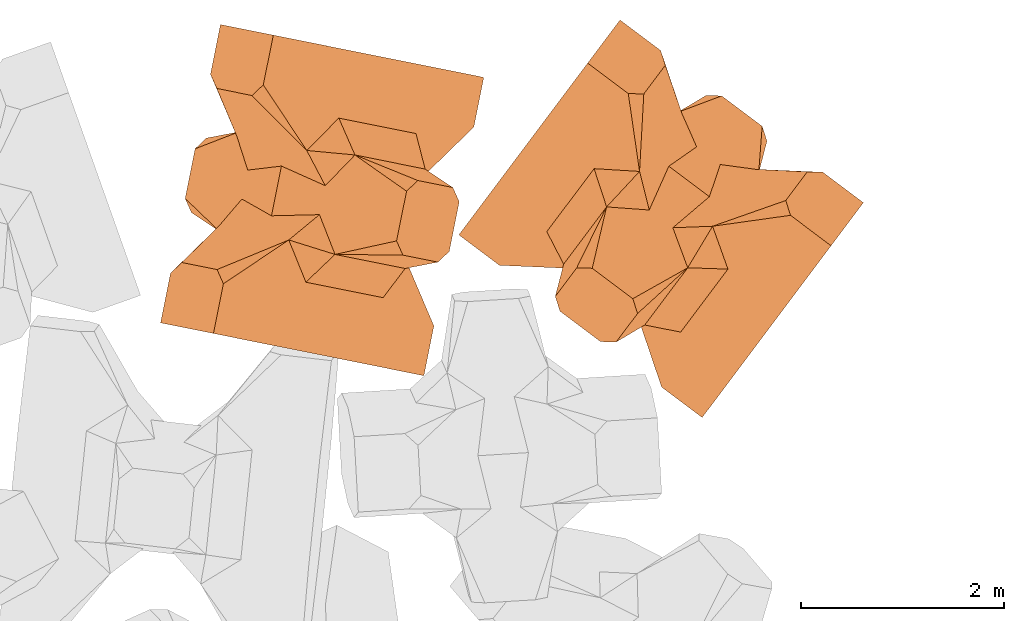
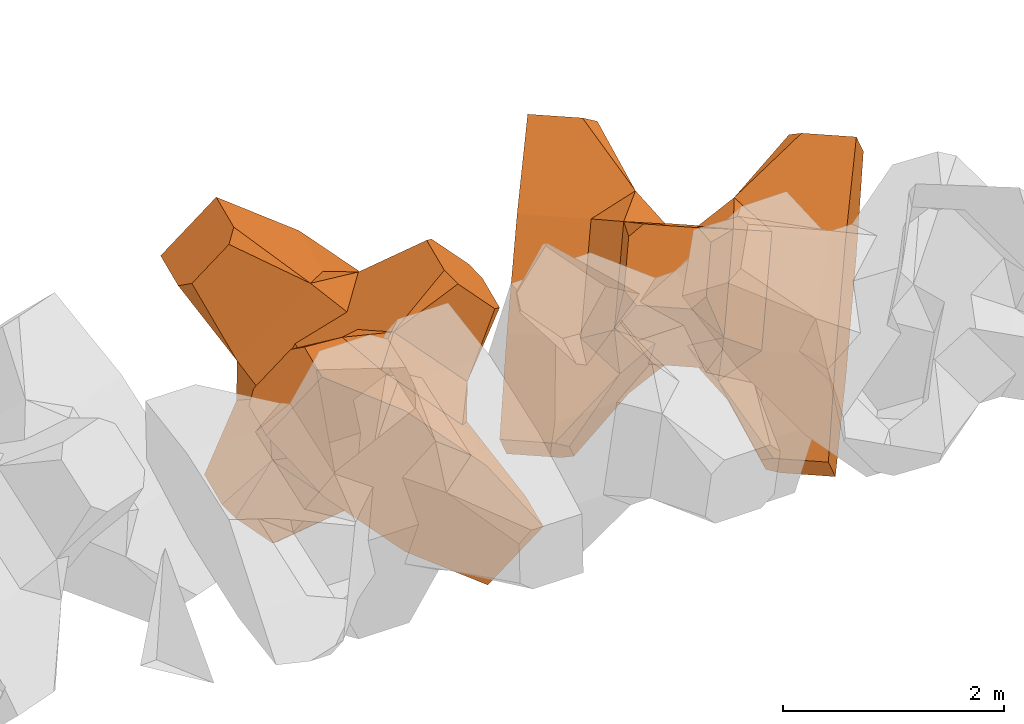
# One storey, part 17 of 17: 2 civil elements.
"""IFC4 building model written with IfcOpenShell, lengths in metres."""

from ifc_helpers import new_model, entity, si_unit, converted_unit, frame, origin_with_axes, origin_2d_with_axis, place, context, subcontext, project, spatial, polygons, element, save


model = new_model("IFC4")

# Units and contexts
model_context = context("Model", 3, precision=1e-05, world=origin_with_axes())
plan_context = context("Plan", 2, precision=1e-05, world=origin_2d_with_axis())
body_context = subcontext(model_context, "Body", "Model", "MODEL_VIEW")
ifc_project = project(units=[si_unit("VOLUMEUNIT", "CUBIC_METRE"), si_unit("LENGTHUNIT", "METRE"), converted_unit("PLANEANGLEUNIT", "degree", entity("IfcReal", 0.0174532925199433), si_unit("PLANEANGLEUNIT", "RADIAN"), dimensions=[0, 0, 0, 0, 0, 0, 0]), si_unit("AREAUNIT", "SQUARE_METRE")], contexts=[model_context, plan_context])

# Site, building, storey
site_placement = place(None, origin_with_axes())
site = spatial("IfcSite", under=ifc_project, at=site_placement)
building_placement = place(site_placement, origin_with_axes())
building = spatial("IfcBuilding", under=site, at=building_placement, Name="Building")
storey_placement = place(building_placement, origin_with_axes())
storey = spatial("IfcBuildingStorey", under=building, at=storey_placement, Name="Storey")

# Civil elements
civil_element_1_placement = place(storey_placement, frame((19.1886653900146, 20.6049900054932, 2.36769986152649), z_axis=(-0.694805041459192, 0.139426115266262, -0.705553904917724), x_axis=(-0.691766307032722, 0.138800990627005, 0.708656236447033)))
element("IfcCivilElement", 1, at=civil_element_1_placement, inside=storey, ObjectType="IfcCivilElementType", context=body_context, shape_type="Tessellation", body=[
    polygons([(0.50000011920929, 0.500000059604645, 0.821428656578064), (0.374999821186066, 0.249999940395355, 1.5), (0.550000011920929, 0.145680621266365, 0.550000071525574), (0.374999821186066, -0.250000029802322, 1.5), (0.651315808296204, -0.250000029802322, 1.45970545872842e-07), (0.651315808296204, 0.249999940395355, 1.45970545872842e-07), (0.550000011920929, -0.145680695772171, 0.550000071525574), (0.50000011920929, -0.500000059604645, 0.821428656578064), (-0.25, 0.374999791383743, 1.5), (0.249999970197678, 0.374999791383743, 1.5), (-0.500000059604645, 0.500000059604645, 0.821428656578064), (-0.550000011920929, 0.824999988079071, 0.550000071525574), (0.550000011920929, 0.824999988079071, 0.550000071525574), (-0.550000011920929, 1.5, 0.550000071525574), (0.550000011920929, 1.5, 0.550000071525574), (-0.25, -0.375, 1.5), (0.249999970197678, -0.375, 1.5), (-0.374999970197678, -0.250000029802322, 1.5), (-0.374999970197678, 0.249999940395355, 1.5), (1.5, 0.87499988079071, -0.249999806284904), (1.5, 0.87499988079071, 0.25000011920929), (0.845557510852814, 0.449999898672104, -0.495555102825165), (0.845557510852814, 0.449999898672104, 0.495555102825165), (1.5, 1.5, -0.374999791383743), (1.5, 1.5, 0.374999940395355), (1.5, 1.0, -0.374999791383743), (1.5, 1.0, 0.374999940395355), (-1.5, 1.5, -0.374999791383743), (-1.5, 1.5, 0.374999940395355), (-0.550000011920929, 1.5, -0.54999977350235), (0.550000011920929, 1.5, -0.54999977350235), (0.550000011920929, 0.145680621266365, -0.54999977350235), (-0.500000059604645, -0.500000059604645, 0.821428656578064), (-0.550000011920929, -0.145680695772171, 0.550000071525574), (-0.651315808296204, 0.249999940395355, 1.45970545872842e-07), (-0.651315808296204, -0.250000029802322, 1.45970545872842e-07), (-0.550000011920929, 0.145680621266365, 0.550000071525574), (-1.5, 0.87499988079071, 0.25000011920929), (-1.5, 0.87499988079071, -0.249999806284904), (-0.845557391643524, 0.449999898672104, 0.495555102825165), (-0.845557391643524, 0.449999898672104, -0.495555102825165), (-1.5, 1.0, 0.374999940395355), (-1.5, 1.0, -0.374999791383743), (-0.550000011920929, 0.145680621266365, -0.54999977350235), (0.550000011920929, -0.825000107288361, 0.550000071525574), (-0.550000011920929, -0.825000107288361, 0.550000071525574), (0.550000011920929, -1.5, 0.550000071525574), (-0.550000011920929, -1.5, 0.550000071525574), (1.5, -0.875000059604645, 0.25000011920929), (1.5, -0.875000059604645, -0.249999806284904), (0.845557510852814, -0.450000137090683, 0.495555102825165), (0.845557510852814, -0.450000137090683, -0.495555102825165), (1.5, -1.5, 0.374999940395355), (1.5, -1.5, -0.374999791383743), (1.5, -1.00000011920929, 0.374999940395355), (1.5, -1.00000011920929, -0.374999791383743), (0.550000011920929, -1.5, -0.54999977350235), (-0.550000011920929, -1.5, -0.54999977350235), (-1.5, -1.5, -0.374999791383743), (-1.5, -1.5, 0.374999940395355), (0.550000011920929, -0.145680695772171, -0.54999977350235), (-1.5, -0.875000059604645, -0.249999806284904), (-1.5, -0.875000059604645, 0.25000011920929), (-0.845557391643524, -0.450000137090683, -0.495555102825165), (-0.845557391643524, -0.450000137090683, 0.495555102825165), (-1.5, -1.00000011920929, -0.374999791383743), (-1.5, -1.00000011920929, 0.374999940395355), (-0.550000011920929, -0.145680695772171, -0.54999977350235), (0.50000011920929, -0.500000059604645, -0.821428418159485), (0.374999821186066, -0.250000029802322, -1.49999976158142), (0.374999821186066, 0.249999940395355, -1.49999976158142), (0.50000011920929, 0.500000059604645, -0.821428418159485), (0.249999970197678, 0.374999791383743, -1.49999976158142), (-0.25, 0.374999791383743, -1.49999976158142), (-0.500000059604645, 0.500000059604645, -0.821428418159485), (0.550000011920929, 0.824999988079071, -0.54999977350235), (-0.550000011920929, 0.824999988079071, -0.54999977350235), (0.249999970197678, -0.375, -1.49999976158142), (-0.25, -0.375, -1.49999976158142), (-0.374999970197678, -0.250000029802322, -1.49999976158142), (-0.374999970197678, 0.249999940395355, -1.49999976158142), (-0.500000059604645, -0.500000059604645, -0.821428418159485), (-0.550000011920929, -0.825000107288361, -0.54999977350235), (0.550000011920929, -0.825000107288361, -0.54999977350235)], [[[1, 2, 3]], [[3, 2, 4]], [[5, 6, 7]], [[7, 6, 3]], [[7, 3, 8]], [[8, 3, 4]], [[9, 10, 11]], [[11, 10, 1]], [[12, 13, 14]], [[14, 13, 15]], [[16, 17, 18]], [[18, 17, 4]], [[18, 4, 19]], [[19, 4, 2]], [[19, 2, 9]], [[9, 2, 10]], [[20, 21, 22]], [[22, 21, 23]], [[24, 25, 26]], [[26, 25, 27]], [[26, 27, 20]], [[20, 27, 21]], [[23, 27, 13]], [[13, 27, 25]], [[13, 25, 15]], [[28, 29, 30]], [[30, 29, 14]], [[30, 14, 31]], [[31, 14, 15]], [[31, 15, 24]], [[24, 15, 25]], [[21, 27, 23]], [[2, 1, 10]], [[13, 12, 1]], [[1, 12, 11]], [[13, 1, 23]], [[32, 22, 6]], [[6, 22, 23]], [[6, 23, 3]], [[3, 23, 1]], [[33, 18, 34]], [[34, 18, 19]], [[35, 36, 37]], [[37, 36, 34]], [[37, 34, 11]], [[11, 34, 19]], [[38, 39, 40]], [[40, 39, 41]], [[29, 28, 42]], [[42, 28, 43]], [[42, 43, 38]], [[38, 43, 39]], [[14, 29, 12]], [[12, 29, 42]], [[12, 42, 40]], [[40, 42, 38]], [[9, 11, 19]], [[40, 11, 12]], [[37, 40, 35]], [[35, 40, 41]], [[35, 41, 44]], [[11, 40, 37]], [[17, 16, 8]], [[8, 16, 33]], [[45, 46, 47]], [[47, 46, 48]], [[49, 50, 51]], [[51, 50, 52]], [[53, 54, 55]], [[55, 54, 56]], [[55, 56, 49]], [[49, 56, 50]], [[47, 53, 45]], [[45, 53, 55]], [[45, 55, 51]], [[54, 53, 57]], [[57, 53, 47]], [[57, 47, 58]], [[58, 47, 48]], [[58, 48, 59]], [[59, 48, 60]], [[51, 55, 49]], [[17, 8, 4]], [[46, 45, 33]], [[33, 45, 8]], [[51, 8, 45]], [[7, 51, 5]], [[5, 51, 52]], [[5, 52, 61]], [[8, 51, 7]], [[62, 63, 64]], [[64, 63, 65]], [[59, 60, 66]], [[66, 60, 67]], [[66, 67, 62]], [[62, 67, 63]], [[65, 67, 46]], [[46, 67, 60]], [[46, 60, 48]], [[63, 67, 65]], [[18, 33, 16]], [[46, 33, 65]], [[68, 64, 36]], [[36, 64, 65]], [[36, 65, 34]], [[34, 65, 33]], [[69, 70, 61]], [[61, 70, 71]], [[6, 5, 32]], [[32, 5, 61]], [[32, 61, 72]], [[72, 61, 71]], [[73, 74, 72]], [[72, 74, 75]], [[76, 77, 31]], [[31, 77, 30]], [[78, 79, 70]], [[70, 79, 80]], [[70, 80, 71]], [[71, 80, 81]], [[71, 81, 73]], [[73, 81, 74]], [[31, 24, 76]], [[76, 24, 26]], [[76, 26, 22]], [[22, 26, 20]], [[73, 72, 71]], [[77, 76, 75]], [[75, 76, 72]], [[22, 72, 76]], [[72, 22, 32]], [[75, 81, 44]], [[44, 81, 80]], [[36, 35, 68]], [[68, 35, 44]], [[68, 44, 82]], [[82, 44, 80]], [[41, 43, 77]], [[77, 43, 28]], [[77, 28, 30]], [[39, 43, 41]], [[81, 75, 74]], [[77, 75, 41]], [[44, 41, 75]], [[79, 78, 82]], [[82, 78, 69]], [[83, 84, 58]], [[58, 84, 57]], [[52, 56, 84]], [[84, 56, 54]], [[84, 54, 57]], [[50, 56, 52]], [[70, 69, 78]], [[84, 83, 69]], [[69, 83, 82]], [[84, 69, 52]], [[61, 52, 69]], [[58, 59, 83]], [[83, 59, 66]], [[83, 66, 64]], [[64, 66, 62]], [[79, 82, 80]], [[64, 82, 83]], [[82, 64, 68]]], closed=True),
])
civil_element_2_placement = place(storey_placement, frame((22.5301284790039, 20.4211540222168, 2.36751890182495), z_axis=(0.425252485670972, 0.566642626663987, -0.705745320266452), x_axis=(0.423636763276199, 0.564454017721615, 0.708465634084528)))
element("IfcCivilElement", 2, at=civil_element_2_placement, inside=storey, ObjectType="IfcCivilElementType", context=body_context, shape_type="Tessellation", body=[
    polygons([(0.500000059604645, 0.500000059604645, 0.821428835391998), (0.374999791383743, 0.249999940395355, 1.50000035762787), (0.549999952316284, 0.145680621266365, 0.550000190734863), (0.374999791383743, -0.250000029802322, 1.50000035762787), (0.651315748691559, -0.250000029802322, 1.45970574294552e-07), (0.651315748691559, 0.249999940395355, 1.45970574294552e-07), (0.549999952316284, -0.145680695772171, 0.550000190734863), (0.500000059604645, -0.500000059604645, 0.821428835391998), (-0.249999970197678, 0.374999791383743, 1.50000035762787), (0.249999940395355, 0.374999791383743, 1.50000035762787), (-0.5, 0.500000059604645, 0.821428835391998), (-0.549999952316284, 0.824999988079071, 0.550000190734863), (0.549999952316284, 0.824999988079071, 0.550000190734863), (-0.549999952316284, 1.5, 0.550000190734863), (0.549999952316284, 1.5, 0.550000190734863), (-0.249999970197678, -0.375, 1.50000035762787), (0.249999940395355, -0.375, 1.50000035762787), (-0.374999940395355, -0.250000029802322, 1.50000035762787), (-0.374999940395355, 0.249999940395355, 1.50000035762787), (1.49999988079071, 0.87499988079071, -0.249999865889549), (1.49999988079071, 0.87499988079071, 0.250000149011612), (0.845557451248169, 0.449999898672104, -0.495555222034454), (0.845557451248169, 0.449999898672104, 0.495555222034454), (1.49999988079071, 1.5, -0.374999850988388), (1.49999988079071, 1.5, 0.375), (1.49999988079071, 1.0, -0.374999850988388), (1.49999988079071, 1.0, 0.375), (-1.49999988079071, 1.5, -0.374999850988388), (-1.49999988079071, 1.5, 0.375), (-0.549999952316284, 1.5, -0.549999892711639), (0.549999952316284, 1.5, -0.549999892711639), (0.549999952316284, 0.145680621266365, -0.549999892711639), (-0.5, -0.500000059604645, 0.821428835391998), (-0.549999952316284, -0.145680695772171, 0.550000190734863), (-0.651315748691559, 0.249999940395355, 1.45970574294552e-07), (-0.651315748691559, -0.250000029802322, 1.45970574294552e-07), (-0.549999952316284, 0.145680621266365, 0.550000190734863), (-1.49999988079071, 0.87499988079071, 0.250000149011612), (-1.49999988079071, 0.87499988079071, -0.249999865889549), (-0.845557332038879, 0.449999898672104, 0.495555222034454), (-0.845557332038879, 0.449999898672104, -0.495555222034454), (-1.49999988079071, 1.0, 0.375), (-1.49999988079071, 1.0, -0.374999850988388), (-0.549999952316284, 0.145680621266365, -0.549999892711639), (0.549999952316284, -0.825000107288361, 0.550000190734863), (-0.549999952316284, -0.825000107288361, 0.550000190734863), (0.549999952316284, -1.5, 0.550000190734863), (-0.549999952316284, -1.5, 0.550000190734863), (1.49999988079071, -0.875000059604645, 0.250000149011612), (1.49999988079071, -0.875000059604645, -0.249999865889549), (0.845557451248169, -0.450000137090683, 0.495555222034454), (0.845557451248169, -0.450000137090683, -0.495555222034454), (1.49999988079071, -1.5, 0.375), (1.49999988079071, -1.5, -0.374999850988388), (1.49999988079071, -1.00000011920929, 0.375), (1.49999988079071, -1.00000011920929, -0.374999850988388), (0.549999952316284, -1.5, -0.549999892711639), (-0.549999952316284, -1.5, -0.549999892711639), (-1.49999988079071, -1.5, -0.374999850988388), (-1.49999988079071, -1.5, 0.375), (0.549999952316284, -0.145680695772171, -0.549999892711639), (-1.49999988079071, -0.875000059604645, -0.249999865889549), (-1.49999988079071, -0.875000059604645, 0.250000149011612), (-0.845557332038879, -0.450000137090683, -0.495555222034454), (-0.845557332038879, -0.450000137090683, 0.495555222034454), (-1.49999988079071, -1.00000011920929, -0.374999850988388), (-1.49999988079071, -1.00000011920929, 0.375), (-0.549999952316284, -0.145680695772171, -0.549999892711639), (0.500000059604645, -0.500000059604645, -0.821428596973419), (0.374999791383743, -0.250000029802322, -1.5), (0.374999791383743, 0.249999940395355, -1.5), (0.500000059604645, 0.500000059604645, -0.821428596973419), (0.249999940395355, 0.374999791383743, -1.5), (-0.249999970197678, 0.374999791383743, -1.5), (-0.5, 0.500000059604645, -0.821428596973419), (0.549999952316284, 0.824999988079071, -0.549999892711639), (-0.549999952316284, 0.824999988079071, -0.549999892711639), (0.249999940395355, -0.375, -1.5), (-0.249999970197678, -0.375, -1.5), (-0.374999940395355, -0.250000029802322, -1.5), (-0.374999940395355, 0.249999940395355, -1.5), (-0.5, -0.500000059604645, -0.821428596973419), (-0.549999952316284, -0.825000107288361, -0.549999892711639), (0.549999952316284, -0.825000107288361, -0.549999892711639)], [[[1, 2, 3]], [[3, 2, 4]], [[5, 6, 7]], [[7, 6, 3]], [[7, 3, 8]], [[8, 3, 4]], [[9, 10, 11]], [[11, 10, 1]], [[12, 13, 14]], [[14, 13, 15]], [[16, 17, 18]], [[18, 17, 4]], [[18, 4, 19]], [[19, 4, 2]], [[19, 2, 9]], [[9, 2, 10]], [[20, 21, 22]], [[22, 21, 23]], [[24, 25, 26]], [[26, 25, 27]], [[26, 27, 20]], [[20, 27, 21]], [[23, 27, 13]], [[13, 27, 25]], [[13, 25, 15]], [[28, 29, 30]], [[30, 29, 14]], [[30, 14, 31]], [[31, 14, 15]], [[31, 15, 24]], [[24, 15, 25]], [[21, 27, 23]], [[2, 1, 10]], [[13, 12, 1]], [[1, 12, 11]], [[13, 1, 23]], [[32, 22, 6]], [[6, 22, 23]], [[6, 23, 3]], [[3, 23, 1]], [[33, 18, 34]], [[34, 18, 19]], [[35, 36, 37]], [[37, 36, 34]], [[37, 34, 11]], [[11, 34, 19]], [[38, 39, 40]], [[40, 39, 41]], [[29, 28, 42]], [[42, 28, 43]], [[42, 43, 38]], [[38, 43, 39]], [[14, 29, 12]], [[12, 29, 42]], [[12, 42, 40]], [[40, 42, 38]], [[9, 11, 19]], [[40, 11, 12]], [[37, 40, 35]], [[35, 40, 41]], [[35, 41, 44]], [[11, 40, 37]], [[17, 16, 8]], [[8, 16, 33]], [[45, 46, 47]], [[47, 46, 48]], [[49, 50, 51]], [[51, 50, 52]], [[53, 54, 55]], [[55, 54, 56]], [[55, 56, 49]], [[49, 56, 50]], [[47, 53, 45]], [[45, 53, 55]], [[45, 55, 51]], [[54, 53, 57]], [[57, 53, 47]], [[57, 47, 58]], [[58, 47, 48]], [[58, 48, 59]], [[59, 48, 60]], [[51, 55, 49]], [[17, 8, 4]], [[46, 45, 33]], [[33, 45, 8]], [[51, 8, 45]], [[7, 51, 5]], [[5, 51, 52]], [[5, 52, 61]], [[8, 51, 7]], [[62, 63, 64]], [[64, 63, 65]], [[59, 60, 66]], [[66, 60, 67]], [[66, 67, 62]], [[62, 67, 63]], [[65, 67, 46]], [[46, 67, 60]], [[46, 60, 48]], [[63, 67, 65]], [[18, 33, 16]], [[46, 33, 65]], [[68, 64, 36]], [[36, 64, 65]], [[36, 65, 34]], [[34, 65, 33]], [[69, 70, 61]], [[61, 70, 71]], [[6, 5, 32]], [[32, 5, 61]], [[32, 61, 72]], [[72, 61, 71]], [[73, 74, 72]], [[72, 74, 75]], [[76, 77, 31]], [[31, 77, 30]], [[78, 79, 70]], [[70, 79, 80]], [[70, 80, 71]], [[71, 80, 81]], [[71, 81, 73]], [[73, 81, 74]], [[31, 24, 76]], [[76, 24, 26]], [[76, 26, 22]], [[22, 26, 20]], [[73, 72, 71]], [[77, 76, 75]], [[75, 76, 72]], [[22, 72, 76]], [[72, 22, 32]], [[75, 81, 44]], [[44, 81, 80]], [[36, 35, 68]], [[68, 35, 44]], [[68, 44, 82]], [[82, 44, 80]], [[41, 43, 77]], [[77, 43, 28]], [[77, 28, 30]], [[39, 43, 41]], [[81, 75, 74]], [[77, 75, 41]], [[44, 41, 75]], [[79, 78, 82]], [[82, 78, 69]], [[83, 84, 58]], [[58, 84, 57]], [[52, 56, 84]], [[84, 56, 54]], [[84, 54, 57]], [[50, 56, 52]], [[70, 69, 78]], [[84, 83, 69]], [[69, 83, 82]], [[84, 69, 52]], [[61, 52, 69]], [[58, 59, 83]], [[83, 59, 66]], [[83, 66, 64]], [[64, 66, 62]], [[79, 82, 80]], [[64, 82, 83]], [[82, 64, 68]]], closed=True),
])

save(model, "model.ifc")
